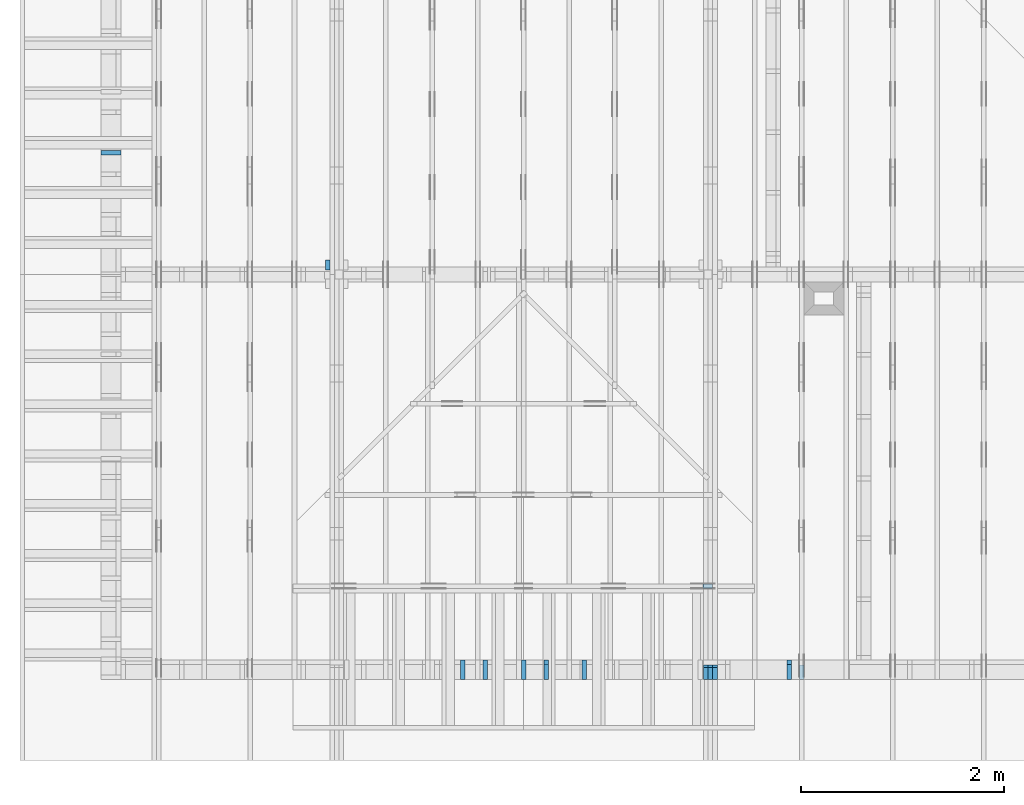
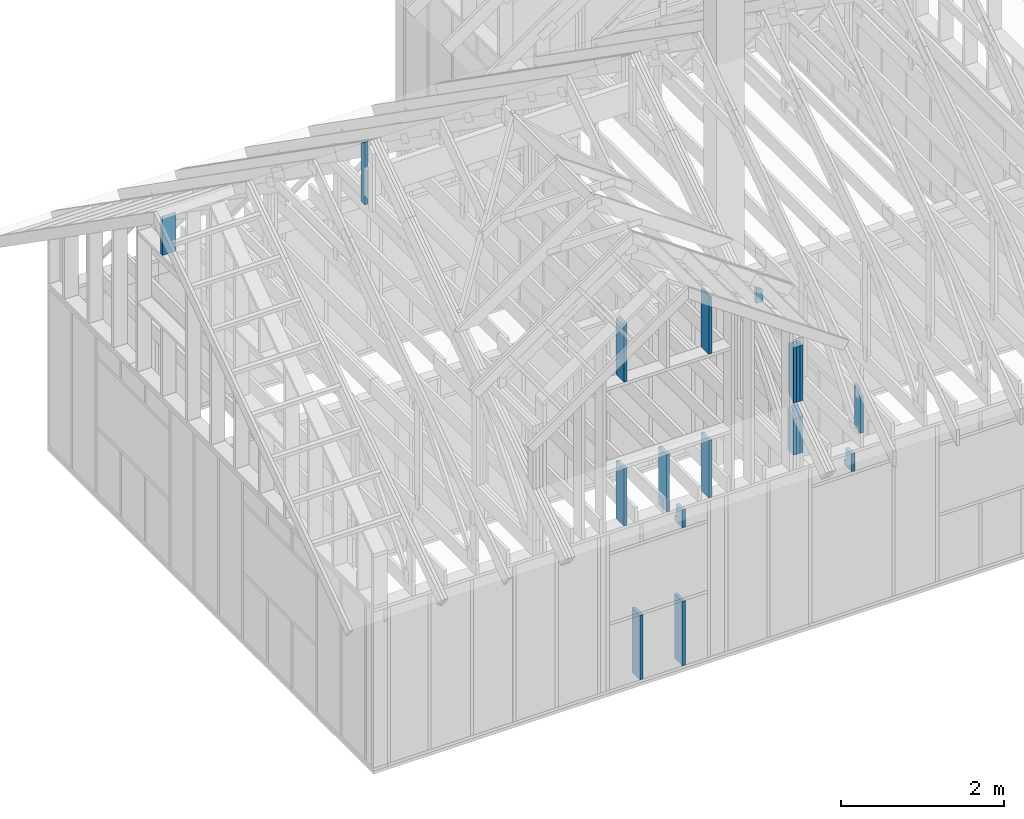
# One storey, part 37 of 70: 19 members, 7 elements without a shape of their own.
"""IFC2X3 building model written with IfcOpenShell, lengths in millimetres."""

from ifc_helpers import new_model, si_unit, frame, origin, origin_with_axes, origin_2d, place, context, project, spatial, faceted_brep, element, aggregate, save


model = new_model("IFC2X3")

# Units and contexts
model_context = context("Model", 3, precision=1e-05, world=origin())
plan_context = context("Plan", 2, precision=1e-05, world=origin_2d())
ifc_project = project(units=[si_unit("LENGTHUNIT", "METRE", prefix="MILLI"), si_unit("AREAUNIT", "SQUARE_METRE"), si_unit("VOLUMEUNIT", "CUBIC_METRE"), si_unit("SOLIDANGLEUNIT", "STERADIAN"), si_unit("PLANEANGLEUNIT", "RADIAN"), si_unit("MASSUNIT", "GRAM"), si_unit("TIMEUNIT", "SECOND"), si_unit("THERMODYNAMICTEMPERATUREUNIT", "DEGREE_CELSIUS"), si_unit("LUMINOUSINTENSITYUNIT", "LUMEN")], contexts=[model_context, plan_context])

# Site, building, storey
site_placement = place(None, origin_with_axes())
site = spatial("IfcSite", under=ifc_project, at=site_placement, CompositionType="ELEMENT")
building_placement = place(site_placement, origin_with_axes())
building = spatial("IfcBuilding", under=site, at=building_placement, Name="Layout 1", CompositionType="ELEMENT")
storey_placement = place(building_placement, origin_with_axes())
storey = spatial("IfcBuildingStorey", under=building, at=storey_placement, Name="Storey 1", CompositionType="ELEMENT", Elevation=0.0)

# Assembly, member
assembly_1_placement = place(storey_placement, frame((1969.9999999999982, 8000.000000000001, 1.1021457184401395e-14), z_axis=(-1.0, 1.836909530733566e-16, 6.123031769111886e-17), x_axis=(-1.836909530733566e-16, -1.0, 0.0)))
assembly_1 = element("IfcElementAssembly", 1, at=assembly_1_placement, inside=storey, Name="T11", AssemblyPlace="FACTORY", PredefinedType="TRUSS")
member_1_placement = place(assembly_1_placement, frame((3954.999999999389, 2824.9999999987776, -45.0), z_axis=(0.0, 0.0, 1.0), x_axis=(6.123031769111886e-17, 1.0, 0.0)))
member_1 = element("IfcMember", 2, at=member_1_placement, Name="BR1", context=model_context, shape_type="Brep", body=[
    faceted_brep([(871.6972245454526, 95.0, 45.0), (0.0, 95.0, 45.0), (0.0, 0.0, 45.0), (938.2169406751927, 0.0, 45.0), (0.0, 95.0, 0.0), (871.6972245454526, 95.0, 1.0674859597876928e-13), (938.2169406751927, 0.0, 1.1489464268146335e-13), (0.0, 0.0, 0.0), (0.0, 0.0, 0.0), (2.755364296100349e-15, -3.3742366240998092e-31, 45.0), (1.4389124657414716e-14, 95.00000000001455, 45.0), (1.1633760361314367e-14, 95.00000000001455, -7.123388428656244e-31), (938.2169406751927, 1.4827130750663824e-11, 1.099279090020205e-29), (938.2169406751927, 1.4829886114959924e-11, 45.0), (-4.354445641813903e-29, 2.755364296100349e-15, 45.0), (0.0, 0.0, 0.0), (871.6972245454526, 95.00000000000006, 0.0), (871.6972245454526, 95.00000000000006, 45.0), (938.2169406751927, 1.5120349416974932e-11, 45.0), (938.2169406751927, 1.5120349416974932e-11, 0.0), (0.0, 95.00000000001455, 0.0), (0.0, 95.00000000001455, 45.0), (871.6972245454526, 94.99999999999999, 45.0), (871.6972245454526, 94.99999999999999, -7.888609052210118e-31)], [[[0, 1, 2, 3]], [[4, 5, 6, 7]], [[8, 9, 10, 11]], [[12, 13, 14, 15]], [[16, 17, 18, 19]], [[20, 21, 22, 23]]]),
])
aggregate(assembly_1, [member_1])

# Assembly, members
assembly_2_placement = place(storey_placement, frame((5660.000000000293, 8000.0, 9.122500660690286e-13), z_axis=(-1.0, 1.836909530733566e-16, 6.123031769111886e-17), x_axis=(-1.836909530733566e-16, -1.0, 0.0)))
assembly_2 = element("IfcElementAssembly", 3, at=assembly_2_placement, inside=storey, Name="T11", AssemblyPlace="FACTORY", PredefinedType="TRUSS")
member_2_placement = place(assembly_2_placement, frame((7855.0, 863.4790482301833, -90.0), z_axis=(0.0, 0.0, 1.0), x_axis=(-1.836909530733566e-16, -1.0, 0.0)))
member_2 = element("IfcMember", 4, at=member_2_placement, Name="E3", context=model_context, shape_type="Brep", body=[
    faceted_brep([(643.4790482301834, 145.0, 45.0), (101.53009304048464, 145.0, 45.0), (0.0, 1.8480932340025902e-09, 45.0), (643.4790482301834, 1.8480932340025902e-09, 45.0), (101.53009304048464, 145.0, 1.2433439704155462e-14), (643.4790482301834, 145.0, 7.880085310142585e-14), (643.4790482301834, 1.8480932340025902e-09, 7.880085310142585e-14), (0.0, 1.8480932340025902e-09, 0.0), (5.452511878872964e-15, 1.8480894161126704e-09, -4.075666256077759e-31), (7.70957417477943e-15, 1.8480878357006368e-09, 45.0), (101.53009304048466, 145.00000000183354, 45.0), (101.53009304048466, 145.00000000183354, 3.1438766626360792e-31), (643.4790482301834, -3.3424355386735616e-13, 2.0465838989515024e-29), (643.4790482301834, -3.314881895712558e-13, 45.0), (7.91492914862017e-27, 1.8480959893668863e-09, 45.0), (0.0, 1.8480932340025902e-09, 0.0), (643.4790482301834, 145.0, 0.0), (643.4790482301834, 145.0, 45.0), (643.4790482301834, 0.0, 45.0), (643.4790482301834, 0.0, 0.0), (101.53009304048464, 145.00000000183357, 1.5777218104420236e-30), (101.53009304048464, 145.00000000183354, 45.0), (643.4790482301834, 145.00000000000006, 45.0), (643.4790482301834, 145.00000000000006, 4.733165431326071e-30)], [[[0, 1, 2, 3]], [[4, 5, 6, 7]], [[8, 9, 10, 11]], [[12, 13, 14, 15]], [[16, 17, 18, 19]], [[20, 21, 22, 23]]]),
])
member_3_placement = place(assembly_2_placement, frame((7855.0, 863.4790482301833, -135.0), z_axis=(0.0, 0.0, 1.0), x_axis=(-1.836909530733566e-16, -1.0, 0.0)))
member_3 = element("IfcMember", 5, at=member_3_placement, Name="E3", context=model_context, shape_type="Brep", body=[
    faceted_brep([(643.4790482301834, 145.0, 45.0), (101.53009304048464, 145.0, 45.0), (0.0, 1.8480932340025902e-09, 45.0), (643.4790482301834, 1.8480932340025902e-09, 45.0), (101.53009304048464, 145.0, 1.2433439704155462e-14), (643.4790482301834, 145.0, 7.880085310142585e-14), (643.4790482301834, 1.8480932340025902e-09, 7.880085310142585e-14), (0.0, 1.8480932340025902e-09, 0.0), (5.452511878872964e-15, 1.8480894161126704e-09, -4.075666256077759e-31), (7.70957417477943e-15, 1.8480878357006368e-09, 45.0), (101.53009304048466, 145.00000000183354, 45.0), (101.53009304048466, 145.00000000183354, 3.1438766626360792e-31), (643.4790482301834, -3.3424355386735616e-13, 2.0465838989515024e-29), (643.4790482301834, -3.314881895712558e-13, 45.0), (7.91492914862017e-27, 1.8480959893668863e-09, 45.0), (0.0, 1.8480932340025902e-09, 0.0), (643.4790482301834, 145.0, 0.0), (643.4790482301834, 145.0, 45.0), (643.4790482301834, 0.0, 45.0), (643.4790482301834, 0.0, 0.0), (101.53009304048464, 145.00000000183357, 1.5777218104420236e-30), (101.53009304048464, 145.00000000183354, 45.0), (643.4790482301834, 145.00000000000006, 45.0), (643.4790482301834, 145.00000000000006, 4.733165431326071e-30)], [[[0, 1, 2, 3]], [[4, 5, 6, 7]], [[8, 9, 10, 11]], [[12, 13, 14, 15]], [[16, 17, 18, 19]], [[20, 21, 22, 23]]]),
])
member_4_placement = place(assembly_2_placement, frame((7855.0, 863.4790482301833, -180.0), z_axis=(0.0, 0.0, 1.0), x_axis=(-1.836909530733566e-16, -1.0, 0.0)))
member_4 = element("IfcMember", 6, at=member_4_placement, Name="E3", context=model_context, shape_type="Brep", body=[
    faceted_brep([(643.4790482301834, 145.0, 45.0), (101.53009304048464, 145.0, 45.0), (0.0, 1.8480932340025902e-09, 45.0), (643.4790482301834, 1.8480932340025902e-09, 45.0), (101.53009304048464, 145.0, 1.2433439704155462e-14), (643.4790482301834, 145.0, 7.880085310142585e-14), (643.4790482301834, 1.8480932340025902e-09, 7.880085310142585e-14), (0.0, 1.8480932340025902e-09, 0.0), (5.452511878872964e-15, 1.8480894161126704e-09, -4.075666256077759e-31), (7.70957417477943e-15, 1.8480878357006368e-09, 45.0), (101.53009304048466, 145.00000000183354, 45.0), (101.53009304048466, 145.00000000183354, 3.1438766626360792e-31), (643.4790482301834, -3.3424355386735616e-13, 2.0465838989515024e-29), (643.4790482301834, -3.314881895712558e-13, 45.0), (7.91492914862017e-27, 1.8480959893668863e-09, 45.0), (0.0, 1.8480932340025902e-09, 0.0), (643.4790482301834, 145.0, 0.0), (643.4790482301834, 145.0, 45.0), (643.4790482301834, 0.0, 45.0), (643.4790482301834, 0.0, 0.0), (101.53009304048464, 145.00000000183357, 1.5777218104420236e-30), (101.53009304048464, 145.00000000183354, 45.0), (643.4790482301834, 145.00000000000006, 45.0), (643.4790482301834, 145.00000000000006, 4.733165431326071e-30)], [[[0, 1, 2, 3]], [[4, 5, 6, 7]], [[8, 9, 10, 11]], [[12, 13, 14, 15]], [[16, 17, 18, 19]], [[20, 21, 22, 23]]]),
])
member_5_placement = place(assembly_2_placement, frame((8000.000000033557, 999.99999997759, -90.0), z_axis=(0.0, 0.0, 1.0), x_axis=(-2.7770506434796755e-12, 1.0, 0.0)))
member_5 = element("IfcMember", 7, at=member_5_placement, Name="E5", context=model_context, shape_type="Brep", body=[
    faceted_brep([(830.4396159941855, 120.00000002938759, 45.0), (84.0249045856458, 120.00000002938759, 45.0), (0.0, 0.0, 45.0), (830.4396159939456, 0.0, 45.0), (84.0249045856458, 120.00000002938759, 1.0289743203490085e-14), (830.4396159941855, 120.00000002938759, 1.0169616302122946e-13), (830.4396159939456, 0.0, 1.0169616302120009e-13), (0.0, 0.0, 0.0), (0.0, 0.0, 0.0), (2.2570622959073368e-15, -1.580412033812092e-15, 45.0), (84.02490458564581, 120.00000000001366, 45.0), (84.02490458564581, 120.00000000001366, 0.0), (830.4396159939456, 3.124957528378116e-08, 4.057544176123283e-29), (830.4396159939456, 3.124957803914546e-08, 45.0), (-1.0368479820435048e-25, 2.755364296100349e-15, 45.0), (0.0, 0.0, 0.0), (830.4396159939456, 120.00000002938759, -1.4685434611594356e-26), (830.4396159939456, 120.00000002938759, 45.0), (830.4396159939456, 3.1250237952917814e-08, 45.0), (830.4396159939456, 3.1250237952917814e-08, 0.0), (84.02490458564579, 120.00000000001364, 0.0), (84.02490458564579, 120.00000000001363, 45.0), (830.4396159941855, 120.00000002938755, 45.0), (830.4396159941855, 120.00000002938755, -3.1554436208840472e-30)], [[[0, 1, 2, 3]], [[4, 5, 6, 7]], [[8, 9, 10, 11]], [[12, 13, 14, 15]], [[16, 17, 18, 19]], [[20, 21, 22, 23]]]),
])
member_6_placement = place(assembly_2_placement, frame((8000.000000033557, 999.99999997759, -135.0), z_axis=(0.0, 0.0, 1.0), x_axis=(-2.7770506434796755e-12, 1.0, 0.0)))
member_6 = element("IfcMember", 8, at=member_6_placement, Name="E5", context=model_context, shape_type="Brep", body=[
    faceted_brep([(830.4396159941855, 120.00000002938759, 45.0), (84.0249045856458, 120.00000002938759, 45.0), (0.0, 0.0, 45.0), (830.4396159939456, 0.0, 45.0), (84.0249045856458, 120.00000002938759, 1.0289743203490085e-14), (830.4396159941855, 120.00000002938759, 1.0169616302122946e-13), (830.4396159939456, 0.0, 1.0169616302120009e-13), (0.0, 0.0, 0.0), (0.0, 0.0, 0.0), (2.2570622959073368e-15, -1.580412033812092e-15, 45.0), (84.02490458564581, 120.00000000001366, 45.0), (84.02490458564581, 120.00000000001366, 0.0), (830.4396159939456, 3.124957528378116e-08, 4.057544176123283e-29), (830.4396159939456, 3.124957803914546e-08, 45.0), (-1.0368479820435048e-25, 2.755364296100349e-15, 45.0), (0.0, 0.0, 0.0), (830.4396159939456, 120.00000002938759, -1.4685434611594356e-26), (830.4396159939456, 120.00000002938759, 45.0), (830.4396159939456, 3.1250237952917814e-08, 45.0), (830.4396159939456, 3.1250237952917814e-08, 0.0), (84.02490458564579, 120.00000000001364, 0.0), (84.02490458564579, 120.00000000001363, 45.0), (830.4396159941855, 120.00000002938755, 45.0), (830.4396159941855, 120.00000002938755, -3.1554436208840472e-30)], [[[0, 1, 2, 3]], [[4, 5, 6, 7]], [[8, 9, 10, 11]], [[12, 13, 14, 15]], [[16, 17, 18, 19]], [[20, 21, 22, 23]]]),
])
member_7_placement = place(assembly_2_placement, frame((8000.000000033557, 999.99999997759, -180.0), z_axis=(0.0, 0.0, 1.0), x_axis=(-2.7770506434796755e-12, 1.0, 0.0)))
member_7 = element("IfcMember", 9, at=member_7_placement, Name="E5", context=model_context, shape_type="Brep", body=[
    faceted_brep([(830.4396159941855, 120.00000002938759, 45.0), (84.0249045856458, 120.00000002938759, 45.0), (0.0, 0.0, 45.0), (830.4396159939456, 0.0, 45.0), (84.0249045856458, 120.00000002938759, 1.0289743203490085e-14), (830.4396159941855, 120.00000002938759, 1.0169616302122946e-13), (830.4396159939456, 0.0, 1.0169616302120009e-13), (0.0, 0.0, 0.0), (0.0, 0.0, 0.0), (2.2570622959073368e-15, -1.580412033812092e-15, 45.0), (84.02490458564581, 120.00000000001366, 45.0), (84.02490458564581, 120.00000000001366, 0.0), (830.4396159939456, 3.124957528378116e-08, 4.057544176123283e-29), (830.4396159939456, 3.124957803914546e-08, 45.0), (-1.0368479820435048e-25, 2.755364296100349e-15, 45.0), (0.0, 0.0, 0.0), (830.4396159939456, 120.00000002938759, -1.4685434611594356e-26), (830.4396159939456, 120.00000002938759, 45.0), (830.4396159939456, 3.1250237952917814e-08, 45.0), (830.4396159939456, 3.1250237952917814e-08, 0.0), (84.02490458564579, 120.00000000001364, 0.0), (84.02490458564579, 120.00000000001363, 45.0), (830.4396159941855, 120.00000002938755, 45.0), (830.4396159941855, 120.00000002938755, -3.1554436208840472e-30)], [[[0, 1, 2, 3]], [[4, 5, 6, 7]], [[8, 9, 10, 11]], [[12, 13, 14, 15]], [[16, 17, 18, 19]], [[20, 21, 22, 23]]]),
])
aggregate(assembly_2, [member_2, member_3, member_4, member_5, member_6, member_7])

# Assembly, member
assembly_3_placement = place(storey_placement, frame((6205.00000000017, 945.0, 1.3776821480501744e-15), z_axis=(1.2246063538223773e-16, 1.0, 6.123031769111886e-17), x_axis=(-1.0, 1.2246063538223773e-16, 0.0)))
assembly_3 = element("IfcElementAssembly", 10, at=assembly_3_placement, inside=storey, Name="T7", AssemblyPlace="FACTORY", PredefinedType="TRUSS")
member_8_placement = place(assembly_3_placement, frame((505.0, 1950.4396159667385, -45.0), z_axis=(0.0, 0.0, 1.0), x_axis=(6.123031769111886e-17, 1.0, 0.0)))
member_8 = element("IfcMember", 11, at=member_8_placement, Name="E6", context=model_context, shape_type="Brep", body=[
    faceted_brep([(168.4906607848452, 95.0000000007276, 45.0), (0.0, 95.0000000007276, 45.0), (0.0, 0.0, 45.0), (235.01037691481815, 0.0, 45.0), (0.0, 95.0000000007276, 0.0), (168.4906607848452, 95.0000000007276, 2.063347337568523e-14), (235.01037691481815, 0.0, 2.8779520078407804e-14), (0.0, 0.0, 0.0), (0.0, 0.0, 0.0), (2.755364296100349e-15, -3.3742366240998092e-31, 45.0), (1.4389124657412933e-14, 95.0, 45.0), (1.1633760361312584e-14, 95.0, -7.123388428655153e-31), (235.01037691481815, 7.273848716768313e-10, 1.291284587053162e-29), (235.01037691481815, 7.273876270411274e-10, 45.0), (-8.528177909643202e-27, 2.755364296100349e-15, 45.0), (0.0, 0.0, 0.0), (168.4906607848452, 95.00000000072761, 3.1554436208840472e-30), (168.4906607848452, 95.00000000072761, 45.0), (235.01037691481818, 7.276099722730578e-10, 45.0), (235.01037691481818, 7.276099722730578e-10, 3.1554436208840472e-30), (0.0, 95.0, 0.0), (0.0, 95.0, 45.0), (168.4906607848452, 95.00000000072758, 45.0), (168.4906607848452, 95.00000000072758, -7.888609052210118e-31)], [[[0, 1, 2, 3]], [[4, 5, 6, 7]], [[8, 9, 10, 11]], [[12, 13, 14, 15]], [[16, 17, 18, 19]], [[20, 21, 22, 23]]]),
])
aggregate(assembly_3, [member_8])

# Assembly, members
assembly_4_placement = place(storey_placement, frame((-48.55339059325575, 0.0, -2470.0), z_axis=(0.0, -1.0, 6.123031769111886e-17), x_axis=(1.0, 0.0, 0.0)))
assembly_4 = element("IfcElementAssembly", 12, at=assembly_4_placement, inside=storey, Name="VE4", AssemblyPlace="FACTORY", PredefinedType="NOTDEFINED")
member_9_placement = place(assembly_4_placement, frame((3577.500000001819, 1055.0, -195.0), z_axis=(0.0, 0.0, 1.0), x_axis=(-1.836909530733566e-16, -1.0, 0.0)))
member_9 = element("IfcMember", 13, at=member_9_placement, Name="S32", context=model_context, shape_type="Brep", body=[
    faceted_brep([(965.0, 45.00000000001455, 195.0), (0.0, 45.00000000001455, 195.0), (0.0, 1.4551915228366852e-11, 195.0), (965.0, 1.4551915228366852e-11, 195.0), (0.0, 45.00000000001455, 0.0), (965.0, 45.00000000001455, 1.181745131438594e-13), (965.0, 1.4551915228366852e-11, 1.181745131438594e-13), (0.0, 1.4551915228366852e-11, 0.0), (1.7820367848942657e-27, 1.4551915228366852e-11, -1.0911467847633593e-43), (1.1939911949769961e-14, 1.4551915228366852e-11, 195.0), (1.745064054197066e-14, 45.00000000001455, 195.0), (5.51072859220248e-15, 45.00000000001455, -3.3742366241009005e-31), (965.0, -1.9591351652949174e-13, 1.1995846857085046e-29), (965.0, -1.8397360457972356e-13, 195.0), (1.8247437996302848e-28, 1.456385514031662e-11, 195.0), (0.0, 1.4551915228366852e-11, 0.0), (965.0, 45.00000000001455, 0.0), (965.0, 45.00000000001455, 195.0), (965.0, 0.0, 195.0), (965.0, 0.0, 0.0), (-1.2154326714572542e-63, 45.00000000001455, 0.0), (-7.31084601888292e-31, 45.00000000001454, 195.0), (965.0, 45.00000000001448, 195.0), (965.0, 45.000000000014495, -3.549874073494553e-30)], [[[0, 1, 2, 3]], [[4, 5, 6, 7]], [[8, 9, 10, 11]], [[12, 13, 14, 15]], [[16, 17, 18, 19]], [[20, 21, 22, 23]]]),
])
member_10_placement = place(assembly_4_placement, frame((4177.500000001819, 2425.0, -195.00000000000003), z_axis=(0.0, 0.0, 1.0), x_axis=(-1.836909530733566e-16, -1.0, 0.0)))
member_10 = element("IfcMember", 14, at=member_10_placement, Name="S40", context=model_context, shape_type="Brep", body=[
    faceted_brep([(0.0, 45.00000000001455, 45.00000000000003), (195.00000000186265, 45.00000000001455, 45.00000000000005), (195.00000000186265, 0.0, 45.00000000000005), (0.0, 0.0, 45.00000000000003), (195.00000000186265, 45.00000000001455, 2.842170943040401e-14), (195.00000000186265, 45.00000000001455, 45.00000000000003), (195.00000000186265, 1.0913936421275139e-11, 45.00000000000003), (195.00000000186265, 1.0913936421275139e-11, 2.842170943040401e-14), (2.7553642961003504e-15, -3.3742366240998114e-31, 45.00000000000003), (1.1939911949768181e-14, -1.4621692037765844e-30, 195.00000000000006), (1.7450640541970662e-14, 45.00000000001455, 195.00000000000006), (8.26609288830283e-15, 45.00000000001455, 45.00000000000003), (270.0, -4.959655732980628e-14, 2.842170943040401e-14), (270.0, -3.76566453800381e-14, 195.00000000000003), (2.1932538056648764e-30, 1.193991194976818e-14, 195.00000000000003), (5.061354936149717e-31, 2.7553642961003504e-15, 45.00000000000003), (195.00000000186265, -3.306437155354634e-14, 45.00000000000003), (195.00000000186265, -3.5819735849646686e-14, 2.842170943040401e-14), (-1.6871183120499057e-31, 45.00000000001455, 45.00000000000003), (-7.310846018882921e-31, 45.00000000001454, 195.00000000000003), (270.0, 45.00000000001452, 195.00000000000003), (270.0, 45.00000000001454, 2.8421709430404004e-14), (195.00000000186265, 45.00000000001454, 2.8421709430404004e-14), (195.00000000186265, 45.00000000001454, 45.00000000000003), (270.0, 45.00000000001455, 0.0), (270.0, 45.00000000001455, 195.00000000000003), (270.0, 1.4551915228366852e-11, 195.00000000000003), (270.0, 1.4551915228366852e-11, 0.0), (270.0, 45.00000000001455, 195.00000000000003), (0.0, 45.00000000001455, 195.00000000000003), (0.0, 0.0, 195.00000000000003), (270.0, 0.0, 195.00000000000003), (195.00000000186265, 45.00000000001455, 5.2301533330168465e-14), (270.0, 45.00000000001455, 6.148608098360819e-14), (270.0, 1.4551915228366852e-11, 6.148608098360819e-14), (195.00000000186265, 1.4551915228366852e-11, 5.2301533330168465e-14)], [[[0, 1, 2, 3]], [[4, 5, 6, 7]], [[8, 9, 10, 11]], [[12, 13, 14, 15, 16, 17]], [[18, 19, 20, 21, 22, 23]], [[24, 25, 26, 27]], [[28, 29, 30, 31]], [[32, 33, 34, 35]]]),
])
member_11_placement = place(assembly_4_placement, frame((4177.499999992942, 1055.0, -195.0), z_axis=(0.0, 0.0, 1.0), x_axis=(7.044874666267686e-16, -1.0, 0.0)))
member_11 = element("IfcMember", 15, at=member_11_placement, Name="S32", context=model_context, shape_type="Brep", body=[
    faceted_brep([(965.0, 45.00000000001364, 195.0), (0.0, 45.00000000001364, 195.0), (0.0, 0.0, 195.0), (965.0, 0.0, 195.0), (0.0, 45.00000000001364, 0.0), (965.0, 45.00000000001364, 1.181745131438594e-13), (965.0, 0.0, 1.181745131438594e-13), (0.0, 0.0, 0.0), (0.0, 0.0, 0.0), (1.1939911949768178e-14, -1.462169203776584e-30, 195.0), (1.745064054197066e-14, 45.00000000001455, 195.0), (5.51072859220248e-15, 45.00000000001455, -3.3742366241009005e-31), (965.0, 1.3536213030454144e-11, 6.503118729816954e-30), (965.0, 1.3548152942403913e-11, 195.0), (-1.67483100224795e-28, 1.1939911949768178e-14, 195.0), (0.0, 0.0, 0.0), (965.0, 45.00000000001364, 0.0), (965.0, 45.00000000001364, 195.0), (965.0, 1.3642420526593924e-11, 195.0), (965.0, 1.3642420526593924e-11, 0.0), (0.0, 45.00000000001455, 0.0), (-1.262177448353619e-29, 45.00000000001454, 195.0), (965.0, 45.00000000001362, 195.0), (965.0, 45.000000000013635, -3.944304526105059e-31)], [[[0, 1, 2, 3]], [[4, 5, 6, 7]], [[8, 9, 10, 11]], [[12, 13, 14, 15]], [[16, 17, 18, 19]], [[20, 21, 22, 23]]]),
])
member_12_placement = place(assembly_4_placement, frame((6577.500000001819, 2425.0, -195.00000000000003), z_axis=(0.0, 0.0, 1.0), x_axis=(-1.836909530733566e-16, -1.0, 0.0)))
member_12 = element("IfcMember", 16, at=member_12_placement, Name="S40", context=model_context, shape_type="Brep", body=[
    faceted_brep([(0.0, 45.0, 45.00000000000003), (195.00000000186265, 45.0, 45.00000000000005), (195.00000000186265, 1.4551915228366852e-11, 45.00000000000005), (0.0, 1.4551915228366852e-11, 45.00000000000003), (195.00000000186265, 45.0, 2.842170943040401e-14), (195.00000000186265, 45.0, 45.00000000000003), (195.00000000186265, 3.637978807091713e-12, 45.00000000000003), (195.00000000186265, 3.637978807091713e-12, 2.842170943040401e-14), (2.7553642961021324e-15, 1.4551915228366852e-11, 45.00000000000003), (1.1939911949769961e-14, 1.4551915228366852e-11, 195.00000000000003), (1.745064054196888e-14, 45.0, 195.00000000000006), (8.266092888301048e-15, 45.0, 45.00000000000003), (270.0, 1.4502318671037046e-11, 2.8421709430404014e-14), (270.0, 1.4514258582986814e-11, 195.00000000000003), (2.1932538056648764e-30, 1.456385514031662e-11, 195.00000000000003), (5.061354936149717e-31, 1.4554670592662952e-11, 45.00000000000003), (195.00000000186265, 1.4518850856813305e-11, 45.00000000000003), (195.00000000186265, 1.4516095492517205e-11, 2.8421709430404014e-14), (-1.6871183120499057e-31, 45.0, 45.00000000000003), (-7.310846018882921e-31, 44.999999999999986, 195.00000000000003), (270.0, 44.99999999999997, 195.00000000000003), (270.0, 44.999999999999986, 2.842170943040401e-14), (195.00000000186265, 44.999999999999986, 2.842170943040401e-14), (195.00000000186265, 44.999999999999986, 45.00000000000003), (270.0, 45.0, 0.0), (270.0, 45.0, 195.00000000000003), (270.0, 0.0, 195.00000000000003), (270.0, 0.0, 0.0), (270.0, 45.0, 195.00000000000003), (0.0, 45.0, 195.00000000000003), (0.0, 1.4551915228366852e-11, 195.00000000000003), (270.0, 1.4551915228366852e-11, 195.00000000000003), (195.00000000186265, 45.0, 5.2301533330168465e-14), (270.0, 45.0, 6.148608098360819e-14), (270.0, 0.0, 6.148608098360819e-14), (195.00000000186265, 0.0, 5.2301533330168465e-14)], [[[0, 1, 2, 3]], [[4, 5, 6, 7]], [[8, 9, 10, 11]], [[12, 13, 14, 15, 16, 17]], [[18, 19, 20, 21, 22, 23]], [[24, 25, 26, 27]], [[28, 29, 30, 31]], [[32, 33, 34, 35]]]),
])
aggregate(assembly_4, [member_9, member_10, member_11, member_12])

# Assembly, member
assembly_5_placement = place(storey_placement, frame((-48.55339059327645, 2.2546681725408788e-11, 1.1939911949768178e-14), z_axis=(1.0, 1.156240088482502e-13, 6.123031769111886e-17), x_axis=(-1.156240088482502e-13, 1.0, 0.0)))
assembly_5 = element("IfcElementAssembly", 17, at=assembly_5_placement, inside=storey, Name="VEg1", AssemblyPlace="FACTORY", PredefinedType="NOTDEFINED")
member_13_placement = place(assembly_5_placement, frame((5222.499999999403, 2155.0, -195.0), z_axis=(0.0, 0.0, 1.0), x_axis=(6.123031769111886e-17, 1.0, 0.0)))
member_13 = element("IfcMember", 18, at=member_13_placement, Name="S39", context=model_context, shape_type="Brep", body=[
    faceted_brep([(589.3886047327105, 45.0, 195.0), (0.0, 45.0, 195.0), (0.0, 0.0, 195.0), (557.8792655132638, 0.0, 195.0), (0.0, 45.0, 0.0), (589.3886047327105, 45.0, 7.217690302261829e-14), (557.8792655132638, 0.0, 6.831824932133038e-14), (0.0, 0.0, 0.0), (0.0, 0.0, 0.0), (1.1939911949768178e-14, -1.462169203776584e-30, 195.0), (1.745064054197066e-14, 45.00000000001455, 195.0), (5.51072859220248e-15, 45.00000000001455, -3.3742366241009005e-31), (557.8792655132638, 1.4266916034402084e-11, 1.7450591188175608e-29), (557.8792655132638, 1.4278855946351852e-11, 195.0), (-3.0534513787454363e-28, 1.1939911949768178e-14, 195.0), (0.0, 0.0, 0.0), (589.3886047327106, 44.999999999999886, 1.5777218104420236e-29), (589.3886047327106, 44.999999999999886, 195.0), (557.8792655132639, 1.4438228390645236e-11, 195.0), (557.8792655132639, 1.4438228390645236e-11, 9.466330862652142e-30), (0.0, 45.00000000001455, 0.0), (-2.0194839173657902e-28, 45.00000000001454, 195.0), (589.3886047327105, 45.00000000000011, 195.0), (589.3886047327105, 45.00000000000012, 7.494178599599612e-30)], [[[0, 1, 2, 3]], [[4, 5, 6, 7]], [[8, 9, 10, 11]], [[12, 13, 14, 15]], [[16, 17, 18, 19]], [[20, 21, 22, 23]]]),
])
aggregate(assembly_5, [member_13])

assembly_6_placement = place(storey_placement, frame((6650.000000000001, 8000.0, -9.081170196248781e-13), z_axis=(-1.0, 1.836909530733566e-16, 6.123031769111886e-17), x_axis=(-1.836909530733566e-16, -1.0, 0.0)))
assembly_6 = element("IfcElementAssembly", 19, at=assembly_6_placement, inside=storey, Name="T12", AssemblyPlace="FACTORY", PredefinedType="TRUSS")
member_14_placement = place(assembly_6_placement, frame((7855.0, 863.4790482301833, -45.0), z_axis=(0.0, 0.0, 1.0), x_axis=(-1.836909530733566e-16, -1.0, 0.0)))
member_14 = element("IfcMember", 20, at=member_14_placement, Name="E3", context=model_context, shape_type="Brep", body=[
    faceted_brep([(643.4790482301833, 145.0, 45.0), (101.53009304048464, 145.0, 45.0), (0.0, 1.8480932340025902e-09, 45.0), (643.4790482301833, 1.8480932340025902e-09, 45.0), (101.53009304048464, 145.0, 1.2433439704155462e-14), (643.4790482301833, 145.0, 7.880085310142583e-14), (643.4790482301833, 1.8480932340025902e-09, 7.880085310142583e-14), (0.0, 1.8480932340025902e-09, 0.0), (5.452511878872964e-15, 1.8480894161126704e-09, -4.075666256077759e-31), (7.70957417477943e-15, 1.8480878357006368e-09, 45.0), (101.53009304048466, 145.00000000183354, 45.0), (101.53009304048466, 145.00000000183354, 3.1438766626360792e-31), (643.4790482301833, -3.3424355386714936e-13, 2.0465838989492066e-29), (643.4790482301833, -3.31488189571049e-13, 45.0), (7.91492914862017e-27, 1.8480959893668863e-09, 45.0), (0.0, 1.8480932340025902e-09, 0.0), (643.4790482301833, 145.0, 0.0), (643.4790482301833, 145.0, 45.0), (643.4790482301833, 0.0, 45.0), (643.4790482301833, 0.0, 0.0), (101.53009304048464, 145.00000000183357, 1.5777218104420236e-30), (101.53009304048464, 145.00000000183354, 45.0), (643.4790482301833, 145.00000000000006, 45.0), (643.4790482301833, 145.00000000000006, 4.733165431326071e-30)], [[[0, 1, 2, 3]], [[4, 5, 6, 7]], [[8, 9, 10, 11]], [[12, 13, 14, 15]], [[16, 17, 18, 19]], [[20, 21, 22, 23]]]),
])
aggregate(assembly_6, [member_14])

# Assembly, members
assembly_7_placement = place(storey_placement, frame((5705.000000000031, 195.0, 0.0), z_axis=(1.2246063538223773e-16, 1.0, 6.123031769111886e-17), x_axis=(-1.0, 1.2246063538223773e-16, 0.0)))
assembly_7 = element("IfcElementAssembly", 21, at=assembly_7_placement, inside=storey, Name="VEg2", AssemblyPlace="FACTORY", PredefinedType="NOTDEFINED")
member_15_placement = place(assembly_7_placement, frame((1155.0000000000002, 863.1713847472129, -195.0), z_axis=(0.0, 0.0, 1.0), x_axis=(-1.836909530733566e-16, -1.0, 0.0)))
member_15 = element("IfcMember", 22, at=member_15_placement, Name="S11", context=model_context, shape_type="Brep", body=[
    faceted_brep([(863.1713847472129, 45.0, 195.0), (0.0, 45.0, 195.0), (0.0, 2.2989752324065194e-09, 195.0), (863.1713847472129, 2.2989752324065194e-09, 195.0), (0.0, 45.0, 0.0), (863.1713847472129, 45.0, 1.0570451621990967e-13), (863.1713847472129, 2.2989752324065194e-09, 1.0570451621990967e-13), (0.0, 2.2989752324065194e-09, 0.0), (2.8153396768853e-25, 2.2989752324065194e-09, -1.7238414282409885e-41), (1.1939911950049712e-14, 2.2989752324065194e-09, 195.0), (1.745064054225041e-14, 45.000000002298975, 195.0), (5.510728592482232e-15, 45.000000002298975, -3.3742366242721935e-31), (863.1713847472129, 3.993867196147833e-13, -2.4454575723621513e-29), (863.1713847472129, 4.113266315645515e-13, 195.0), (3.1795300089991984e-26, 2.298987172318469e-09, 195.0), (0.0, 2.2989752324065194e-09, 0.0), (863.1713847472129, 45.0, 0.0), (863.1713847472129, 45.0, 195.0), (863.1713847472129, 0.0, 195.0), (863.1713847472129, 0.0, 0.0), (0.0, 45.000000002298975, 0.0), (-2.5849394142282115e-26, 45.00000000229896, 195.0), (863.1713847472129, 44.999999999999915, 195.0), (863.1713847472129, 44.99999999999993, -4.338734978715565e-30)], [[[0, 1, 2, 3]], [[4, 5, 6, 7]], [[8, 9, 10, 11]], [[12, 13, 14, 15]], [[16, 17, 18, 19]], [[20, 21, 22, 23]]]),
])
member_16_placement = place(assembly_7_placement, frame((1755.0000000000002, 863.1713847472129, -195.0), z_axis=(0.0, 0.0, 1.0), x_axis=(-1.836909530733566e-16, -1.0, 0.0)))
member_16 = element("IfcMember", 23, at=member_16_placement, Name="S34", context=model_context, shape_type="Brep", body=[
    faceted_brep([(863.1713847472128, 45.0, 195.0), (0.0, 45.0, 195.0), (0.0, 2.2989752324065194e-09, 195.0), (863.1713847472128, 2.2989752324065194e-09, 195.0), (0.0, 45.0, 0.0), (863.1713847472128, 45.0, 1.0570451621990966e-13), (863.1713847472128, 2.2989752324065194e-09, 1.0570451621990966e-13), (0.0, 2.2989752324065194e-09, 0.0), (2.8153396768853e-25, 2.2989752324065194e-09, -1.7238414282409885e-41), (1.1939911950049712e-14, 2.2989752324065194e-09, 195.0), (1.745064054225219e-14, 45.00000000231353, 195.0), (5.510728592484014e-15, 45.00000000231353, -3.3742366242732847e-31), (863.1713847472128, 3.993867196151969e-13, -2.4454575723644472e-29), (863.1713847472128, 4.1132663156496507e-13, 195.0), (3.1795300089991984e-26, 2.298987172318469e-09, 195.0), (0.0, 2.2989752324065194e-09, 0.0), (863.1713847472128, 45.0, 0.0), (863.1713847472128, 45.0, 195.0), (863.1713847472128, 0.0, 195.0), (863.1713847472128, 0.0, 0.0), (0.0, 45.00000000231353, 0.0), (-2.5849394142282115e-26, 45.00000000231351, 195.0), (863.1713847472128, 44.9999999999999, 195.0), (863.1713847472128, 44.999999999999915, -5.127595883936577e-30)], [[[0, 1, 2, 3]], [[4, 5, 6, 7]], [[8, 9, 10, 11]], [[12, 13, 14, 15]], [[16, 17, 18, 19]], [[20, 21, 22, 23]]]),
])
member_17_placement = place(assembly_7_placement, frame((2355.0, 863.1713847472129, -195.0), z_axis=(0.0, 0.0, 1.0), x_axis=(-1.836909530733566e-16, -1.0, 0.0)))
member_17 = element("IfcMember", 24, at=member_17_placement, Name="S34", context=model_context, shape_type="Brep", body=[
    faceted_brep([(863.1713847472128, 45.0, 195.0), (0.0, 45.0, 195.0), (0.0, 2.3137545213103294e-09, 195.0), (863.1713847472128, 2.3137545213103294e-09, 195.0), (0.0, 45.0, 0.0), (863.1713847472128, 45.0, 1.0570451621990966e-13), (863.1713847472128, 2.3137545213103294e-09, 1.0570451621990966e-13), (0.0, 2.3137545213103294e-09, 0.0), (2.8334384879818824e-25, 2.3137545213103294e-09, -1.7349233877737414e-41), (1.1939911950051521e-14, 2.3137545213103294e-09, 195.0), (1.745064054225222e-14, 45.000000002313755, 195.0), (5.5107285924840415e-15, 45.000000002313755, -3.3742366242733014e-31), (863.1713847472128, -1.5432830527763368e-13, 9.449571160890398e-30), (863.1713847472128, -1.423883933278655e-13, 195.0), (3.200739553253006e-26, 2.313766461222279e-09, 195.0), (0.0, 2.3137545213103294e-09, 0.0), (863.1713847472128, 45.0, 0.0), (863.1713847472128, 45.0, 195.0), (863.1713847472128, 0.0, 195.0), (863.1713847472128, 0.0, 0.0), (0.0, 45.000000002313755, 0.0), (-2.5849394142282115e-26, 45.00000000231374, 195.0), (863.1713847472128, 45.00000000000013, 195.0), (863.1713847472128, 45.00000000000014, 8.67746995743113e-30)], [[[0, 1, 2, 3]], [[4, 5, 6, 7]], [[8, 9, 10, 11]], [[12, 13, 14, 15]], [[16, 17, 18, 19]], [[20, 21, 22, 23]]]),
])
member_18_placement = place(assembly_7_placement, frame((2355.0000000018626, 3028.3018739855906, -195.0), z_axis=(0.0, 0.0, 1.0), x_axis=(-1.836909530733566e-16, -1.0, 0.0)))
member_18 = element("IfcMember", 25, at=member_18_placement, Name="S33", context=model_context, shape_type="Brep", body=[
    faceted_brep([(873.301873986813, 44.99999999998545, 195.0), (31.50933921932301, 44.99999999998545, 195.0), (0.0, 0.0, 195.0), (873.301873986813, 0.0, 195.0), (31.50933921932301, 44.99999999998545, 3.858653701272758e-15), (873.301873986813, 44.99999999998545, 1.0694510236892403e-13), (873.301873986813, 0.0, 1.0694510236892403e-13), (0.0, 0.0, 0.0), (0.0, 0.0, 0.0), (9.7806032822948e-15, -6.8484521464766876e-15, 195.0), (31.509339219323028, 45.0, 195.0), (31.509339219323017, 45.00000000000001, -3.385621923609464e-31), (873.301873986813, -1.6041765355338603e-13, 9.82242389033767e-30), (873.301873986813, -1.4847774160361785e-13, 195.0), (2.193253805664876e-30, 1.1939911949768178e-14, 195.0), (0.0, 0.0, 0.0), (873.301873986813, 44.99999999998545, 0.0), (873.301873986813, 44.99999999998545, 195.0), (873.301873986813, 0.0, 195.0), (873.301873986813, 0.0, 0.0), (31.50933921932301, 45.0, 0.0), (31.50933921932301, 44.999999999999986, 195.0), (873.301873986813, 44.999999999985356, 195.0), (873.301873986813, 44.99999999998537, -4.733165431326071e-30)], [[[0, 1, 2, 3]], [[4, 5, 6, 7]], [[8, 9, 10, 11]], [[12, 13, 14, 15]], [[16, 17, 18, 19]], [[20, 21, 22, 23]]]),
])
member_19_placement = place(assembly_7_placement, frame((1155.0000000018626, 3028.301873988268, -195.0), z_axis=(0.0, 0.0, 1.0), x_axis=(-1.836909530733566e-16, -1.0, 0.0)))
member_19 = element("IfcMember", 26, at=member_19_placement, Name="S33", context=model_context, shape_type="Brep", body=[
    faceted_brep([(873.3018739894906, 45.0, 195.0), (0.0, 45.0, 195.0), (31.509339219461253, 1.4551915228366852e-11, 195.0), (873.3018739894906, 1.4551915228366852e-11, 195.0), (0.0, 45.0, 0.0), (873.3018739894906, 45.0, 1.0694510236925192e-13), (873.3018739894906, 1.4551915228366852e-11, 1.0694510236925192e-13), (31.509339219461253, 1.4551915228366852e-11, 3.858653701289688e-15), (31.509339219461257, 1.4550138871527452e-11, -4.3790577010150533e-47), (31.509339219461268, 1.4557244298885053e-11, 195.0), (2.1316282072803006e-14, 45.00000000001455, 195.0), (1.0658141036401503e-14, 45.00000000001455, -3.944304526105059e-31), (873.3018739894906, -5.76763746857283e-13, 3.5315427452791473e-29), (873.3018739894906, -5.648238349075148e-13, 195.0), (31.509339219461253, 1.4543045103042576e-11, 195.0), (31.509339219461253, 1.4531105191092808e-11, 1.2742051934537276e-30), (873.3018739894906, 45.0, 0.0), (873.3018739894906, 45.0, 195.0), (873.3018739894906, 0.0, 195.0), (873.3018739894906, 0.0, 0.0), (0.0, 45.00000000001455, 0.0), (-2.0194839173657902e-28, 45.00000000001454, 195.0), (873.3018739894906, 44.99999999999994, 195.0), (873.3018739894906, 44.99999999999996, -2.7610131682735413e-30)], [[[0, 1, 2, 3]], [[4, 5, 6, 7]], [[8, 9, 10, 11]], [[12, 13, 14, 15]], [[16, 17, 18, 19]], [[20, 21, 22, 23]]]),
])
aggregate(assembly_7, [member_15, member_16, member_17, member_18, member_19])

save(model, "model.ifc")
